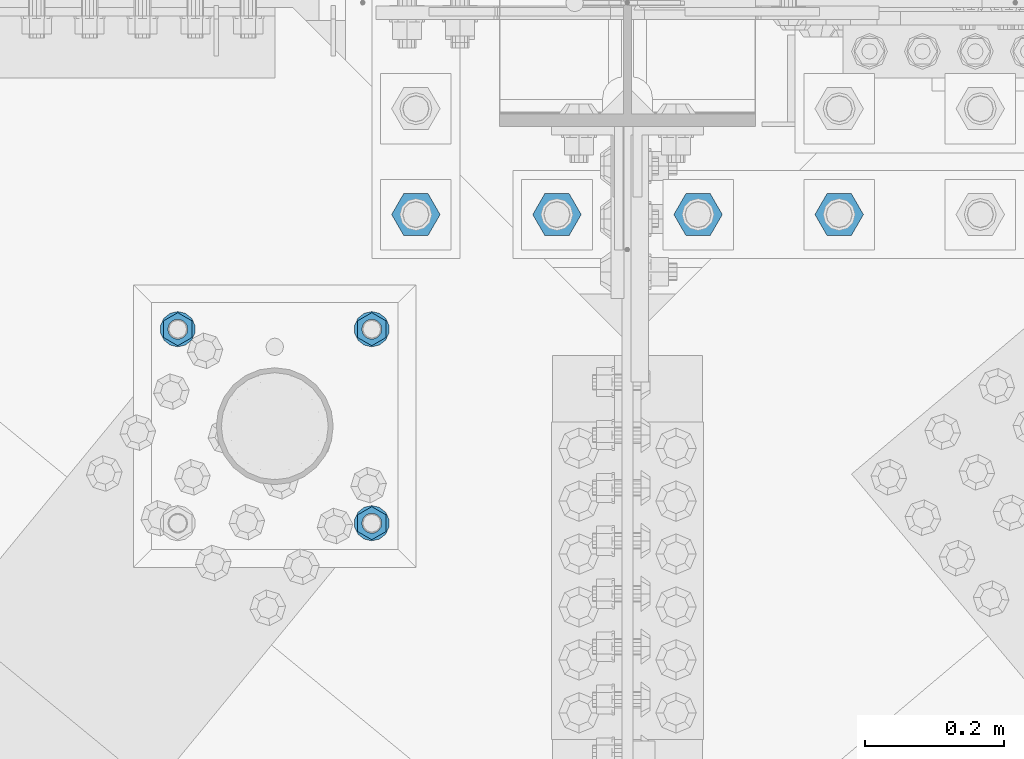
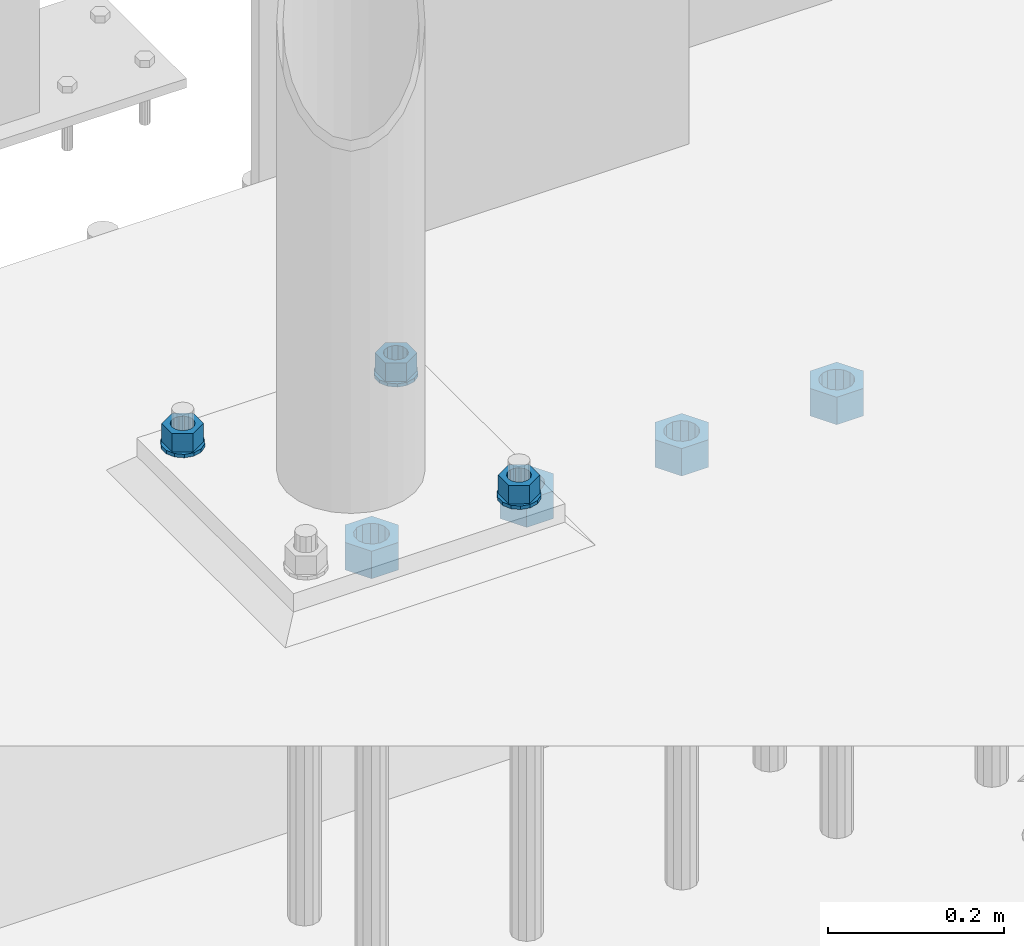
# One storey, part 1706 of 3843: 10 columns, 2 elements without a shape of their own.
"""IFC2X3 building model written with IfcOpenShell, lengths in millimetres."""

from ifc_helpers import new_model, si_unit, frame, origin_with_axes, place, context, subcontext, project, spatial, faceted_brep, material, type_object, element, aggregate, save


model = new_model("IFC2X3")

# Units and contexts
model_context = context("Model", 3, precision=1e-05, world=origin_with_axes())
body_context = subcontext(model_context, "Body", "Model", "MODEL_VIEW")
ifc_project = project(units=[si_unit("LENGTHUNIT", "METRE", prefix="MILLI"), si_unit("AREAUNIT", "SQUARE_METRE"), si_unit("VOLUMEUNIT", "CUBIC_METRE"), si_unit("MASSUNIT", "GRAM", prefix="KILO"), si_unit("TIMEUNIT", "SECOND"), si_unit("PLANEANGLEUNIT", "RADIAN"), si_unit("SOLIDANGLEUNIT", "STERADIAN"), si_unit("THERMODYNAMICTEMPERATUREUNIT", "DEGREE_CELSIUS"), si_unit("LUMINOUSINTENSITYUNIT", "LUMEN")], contexts=[model_context])

# Site, building, storey
site_placement = place(None, origin_with_axes())
site = spatial("IfcSite", under=ifc_project, at=site_placement, CompositionType="ELEMENT")
building_placement = place(site_placement, origin_with_axes())
building = spatial("IfcBuilding", under=site, at=building_placement, Name="Undefined", CompositionType="ELEMENT")
storey_placement = place(building_placement, origin_with_axes())
storey = spatial("IfcBuildingStorey", under=building, at=storey_placement, Name="Undefined", CompositionType="ELEMENT", Elevation=0.0)

# Assembly, columns
assembly_1_placement = place(storey_placement, origin_with_axes())
assembly_1 = element("IfcElementAssembly", 1, at=assembly_1_placement, inside=storey, Name="TEMPLATE", AssemblyPlace="NOTDEFINED", PredefinedType="RIGID_FRAME")
ifc_material = material(Name="STEEL/A572-50")
column_type_1 = type_object("IfcColumnType", Name="1_HEAVY_HEX_NUT", PredefinedType="NOTDEFINED")
column_1_placement = place(assembly_1_placement, frame((48628.3, 91465.4, 30560.9625), z_axis=(1.0, 0.0, 0.0), x_axis=(0.0, 0.0, -1.0)))
column_1 = element("IfcColumn", 2, at=column_1_placement, type_object=column_type_1, material=ifc_material, Name="NUT", ObjectType="1_HEAVY_HEX_NUT", context=body_context, shape_type="Brep", body=[
    faceted_brep([(0.0, -23.8099994659424, 0.0), (0.0, -11.9099998474121, -20.6200008392334), (25.3999999999978, -11.9099998474121, -20.6200008392334), (25.3999999999978, -23.8099994659424, 0.0), (0.0, 11.9099998474121, -20.6200008392334), (25.3999999999978, 11.9099998474121, -20.6200008392334), (0.0, 23.8099994659424, 0.0), (25.3999999999978, 23.8099994659424, 0.0), (0.0, 11.9099998474121, 20.6200008392334), (25.3999999999978, 11.9099998474121, 20.6200008392334), (0.0, -11.9099998474121, 20.6200008392334), (25.3999999999978, -11.9099998474121, 20.6200008392334), (0.0, 0.0, 14.289999961853), (0.0, 6.20019861543551, 12.8748450879575), (25.3999999999978, 6.20019861543551, 12.8748450879575), (25.3999999999978, 0.0, 14.289999961853), (0.0, 11.1723718546418, 8.90966924477834), (25.3999999999978, 11.1723718546418, 8.90966924477834), (0.0, 13.9317198278877, 3.17982413774735), (25.3999999999978, 13.9317198278877, 3.17982413774735), (0.0, 13.9317198278877, -3.17982413774735), (25.3999999999978, 13.9317198278877, -3.17982413774735), (0.0, 11.1723718546418, -8.90966924477834), (25.3999999999978, 11.1723718546418, -8.90966924477834), (0.0, 6.20019861543551, -12.8748450879575), (25.3999999999978, 6.20019861543551, -12.8748450879575), (0.0, 0.0, -14.289999961853), (25.3999999999978, 0.0, -14.289999961853), (0.0, -6.20019861543551, -12.8748450879575), (25.3999999999978, -6.20019861543551, -12.8748450879575), (0.0, -11.1723718546418, -8.90966924477834), (25.3999999999978, -11.1723718546418, -8.90966924477834), (0.0, -13.9317198278877, -3.17982413774735), (25.3999999999978, -13.9317198278877, -3.17982413774735), (0.0, -13.9317198278877, 3.17982413774735), (25.3999999999978, -13.9317198278877, 3.17982413774735), (0.0, -11.1723718546418, 8.90966924477834), (25.3999999999978, -11.1723718546418, 8.90966924477834), (0.0, -6.20019861543551, 12.8748450879575), (25.3999999999978, -6.20019861543551, 12.8748450879575)], [[[0, 1, 2, 3]], [[1, 4, 5, 2]], [[4, 6, 7, 5]], [[6, 8, 9, 7]], [[8, 10, 11, 9]], [[10, 0, 3, 11]], [[12, 13, 14, 15]], [[13, 16, 17, 14]], [[16, 18, 19, 17]], [[18, 20, 21, 19]], [[20, 22, 23, 21]], [[22, 24, 25, 23]], [[24, 26, 27, 25]], [[26, 28, 29, 27]], [[28, 30, 31, 29]], [[30, 32, 33, 31]], [[32, 34, 35, 33]], [[34, 36, 37, 35]], [[36, 38, 39, 37]], [[38, 12, 15, 39]], [[5, 7, 9, 11, 3, 2], [17, 19, 21, 23, 25, 27, 29, 31, 33, 35, 37, 39, 15, 14]], [[10, 8, 6, 4, 1, 0], [38, 36, 34, 32, 30, 28, 26, 24, 22, 20, 18, 16, 13, 12]]]),
])
column_2_placement = place(assembly_1_placement, frame((48628.3, 91744.8, 30560.9625), z_axis=(-1.0, 0.0, 0.0), x_axis=(0.0, 0.0, -1.0)))
column_2 = element("IfcColumn", 3, at=column_2_placement, type_object=column_type_1, material=ifc_material, Name="NUT", ObjectType="1_HEAVY_HEX_NUT", context=body_context, shape_type="Brep", body=[
    faceted_brep([(0.0, -23.8099994659424, 0.0), (0.0, -11.9099998474121, -20.6200008392334), (25.3999999999978, -11.9099998474121, -20.6200008392334), (25.3999999999978, -23.8099994659424, 0.0), (0.0, 11.9099998474121, -20.6200008392334), (25.3999999999978, 11.9099998474121, -20.6200008392334), (0.0, 23.8099994659424, 0.0), (25.3999999999978, 23.8099994659424, 0.0), (0.0, 11.9099998474121, 20.6200008392334), (25.3999999999978, 11.9099998474121, 20.6200008392334), (0.0, -11.9099998474121, 20.6200008392334), (25.3999999999978, -11.9099998474121, 20.6200008392334), (0.0, 0.0, 14.289999961853), (0.0, 6.20019861543551, 12.8748450879575), (25.3999999999978, 6.20019861543551, 12.8748450879575), (25.3999999999978, 0.0, 14.289999961853), (0.0, 11.1723718546418, 8.90966924477834), (25.3999999999978, 11.1723718546418, 8.90966924477834), (0.0, 13.9317198278877, 3.17982413774735), (25.3999999999978, 13.9317198278877, 3.17982413774735), (0.0, 13.9317198278877, -3.17982413774735), (25.3999999999978, 13.9317198278877, -3.17982413774735), (0.0, 11.1723718546418, -8.90966924477834), (25.3999999999978, 11.1723718546418, -8.90966924477834), (0.0, 6.20019861543551, -12.8748450879575), (25.3999999999978, 6.20019861543551, -12.8748450879575), (0.0, 0.0, -14.289999961853), (25.3999999999978, 0.0, -14.289999961853), (0.0, -6.20019861543551, -12.8748450879575), (25.3999999999978, -6.20019861543551, -12.8748450879575), (0.0, -11.1723718546418, -8.90966924477834), (25.3999999999978, -11.1723718546418, -8.90966924477834), (0.0, -13.9317198278877, -3.17982413774735), (25.3999999999978, -13.9317198278877, -3.17982413774735), (0.0, -13.9317198278877, 3.17982413774735), (25.3999999999978, -13.9317198278877, 3.17982413774735), (0.0, -11.1723718546418, 8.90966924477834), (25.3999999999978, -11.1723718546418, 8.90966924477834), (0.0, -6.20019861543551, 12.8748450879575), (25.3999999999978, -6.20019861543551, 12.8748450879575)], [[[0, 1, 2, 3]], [[1, 4, 5, 2]], [[4, 6, 7, 5]], [[6, 8, 9, 7]], [[8, 10, 11, 9]], [[10, 0, 3, 11]], [[12, 13, 14, 15]], [[13, 16, 17, 14]], [[16, 18, 19, 17]], [[18, 20, 21, 19]], [[20, 22, 23, 21]], [[22, 24, 25, 23]], [[24, 26, 27, 25]], [[26, 28, 29, 27]], [[28, 30, 31, 29]], [[30, 32, 33, 31]], [[32, 34, 35, 33]], [[34, 36, 37, 35]], [[36, 38, 39, 37]], [[38, 12, 15, 39]], [[5, 7, 9, 11, 3, 2], [17, 19, 21, 23, 25, 27, 29, 31, 33, 35, 37, 39, 15, 14]], [[10, 8, 6, 4, 1, 0], [38, 36, 34, 32, 30, 28, 26, 24, 22, 20, 18, 16, 13, 12]]]),
])
column_3_placement = place(assembly_1_placement, frame((48348.9, 91744.8, 30560.9625), z_axis=(-1.0, 0.0, 0.0), x_axis=(0.0, 0.0, -1.0)))
column_3 = element("IfcColumn", 4, at=column_3_placement, type_object=column_type_1, material=ifc_material, Name="NUT", ObjectType="1_HEAVY_HEX_NUT", context=body_context, shape_type="Brep", body=[
    faceted_brep([(0.0, -23.8099994659424, 0.0), (0.0, -11.9099998474121, -20.6200008392334), (25.3999999999978, -11.9099998474121, -20.6200008392334), (25.3999999999978, -23.8099994659424, 0.0), (0.0, 11.9099998474121, -20.6200008392334), (25.3999999999978, 11.9099998474121, -20.6200008392334), (0.0, 23.8099994659424, 0.0), (25.3999999999978, 23.8099994659424, 0.0), (0.0, 11.9099998474121, 20.6200008392334), (25.3999999999978, 11.9099998474121, 20.6200008392334), (0.0, -11.9099998474121, 20.6200008392334), (25.3999999999978, -11.9099998474121, 20.6200008392334), (0.0, 0.0, 14.289999961853), (0.0, 6.20019861543551, 12.8748450879575), (25.3999999999978, 6.20019861543551, 12.8748450879575), (25.3999999999978, 0.0, 14.289999961853), (0.0, 11.1723718546418, 8.90966924477834), (25.3999999999978, 11.1723718546418, 8.90966924477834), (0.0, 13.9317198278877, 3.17982413774735), (25.3999999999978, 13.9317198278877, 3.17982413774735), (0.0, 13.9317198278877, -3.17982413774735), (25.3999999999978, 13.9317198278877, -3.17982413774735), (0.0, 11.1723718546418, -8.90966924477834), (25.3999999999978, 11.1723718546418, -8.90966924477834), (0.0, 6.20019861543551, -12.8748450879575), (25.3999999999978, 6.20019861543551, -12.8748450879575), (0.0, 0.0, -14.289999961853), (25.3999999999978, 0.0, -14.289999961853), (0.0, -6.20019861543551, -12.8748450879575), (25.3999999999978, -6.20019861543551, -12.8748450879575), (0.0, -11.1723718546418, -8.90966924477834), (25.3999999999978, -11.1723718546418, -8.90966924477834), (0.0, -13.9317198278877, -3.17982413774735), (25.3999999999978, -13.9317198278877, -3.17982413774735), (0.0, -13.9317198278877, 3.17982413774735), (25.3999999999978, -13.9317198278877, 3.17982413774735), (0.0, -11.1723718546418, 8.90966924477834), (25.3999999999978, -11.1723718546418, 8.90966924477834), (0.0, -6.20019861543551, 12.8748450879575), (25.3999999999978, -6.20019861543551, 12.8748450879575)], [[[0, 1, 2, 3]], [[1, 4, 5, 2]], [[4, 6, 7, 5]], [[6, 8, 9, 7]], [[8, 10, 11, 9]], [[10, 0, 3, 11]], [[12, 13, 14, 15]], [[13, 16, 17, 14]], [[16, 18, 19, 17]], [[18, 20, 21, 19]], [[20, 22, 23, 21]], [[22, 24, 25, 23]], [[24, 26, 27, 25]], [[26, 28, 29, 27]], [[28, 30, 31, 29]], [[30, 32, 33, 31]], [[32, 34, 35, 33]], [[34, 36, 37, 35]], [[36, 38, 39, 37]], [[38, 12, 15, 39]], [[5, 7, 9, 11, 3, 2], [17, 19, 21, 23, 25, 27, 29, 31, 33, 35, 37, 39, 15, 14]], [[10, 8, 6, 4, 1, 0], [38, 36, 34, 32, 30, 28, 26, 24, 22, 20, 18, 16, 13, 12]]]),
])
column_type_2 = type_object("IfcColumnType", Name="1_WASHER", PredefinedType="NOTDEFINED")
column_4_placement = place(assembly_1_placement, frame((48628.3, 91465.4, 30535.5625), z_axis=(1.0, 0.0, 0.0), x_axis=(0.0, 0.0, -1.0)))
column_4 = element("IfcColumn", 5, at=column_4_placement, type_object=column_type_2, material=ifc_material, Name="WASHER", ObjectType="1_WASHER", context=body_context, shape_type="Brep", body=[
    faceted_brep([(0.0, -25.3999996185303, 0.0), (0.0, -22.8846089010331, -11.0206468080723), (4.76250000000073, -22.8846089010331, -11.0206468080723), (4.76250000000073, -25.3999996185303, 0.0), (0.0, -15.8366407293652, -19.8585193564431), (4.76250000000073, -15.8366407293652, -19.8585193564431), (0.0, -5.6520316376118, -24.7631685975139), (4.76250000000073, -5.6520316376118, -24.7631685975139), (0.0, 5.6520316376118, -24.7631685975139), (4.76250000000073, 5.6520316376118, -24.7631685975139), (0.0, 15.8366407293652, -19.8585193564431), (4.76250000000073, 15.8366407293652, -19.8585193564431), (0.0, 22.8846089010331, -11.0206468080723), (4.76250000000073, 22.8846089010331, -11.0206468080723), (0.0, 25.3999996185303, 0.0), (4.76250000000073, 25.3999996185303, 0.0), (0.0, 22.8846089010331, 11.0206468080723), (4.76250000000073, 22.8846089010331, 11.0206468080723), (0.0, 15.8366407293652, 19.8585193564431), (4.76250000000073, 15.8366407293652, 19.8585193564431), (0.0, 5.6520316376118, 24.7631685975139), (4.76250000000073, 5.6520316376118, 24.7631685975139), (0.0, -5.6520316376118, 24.7631685975139), (4.76250000000073, -5.6520316376118, 24.7631685975139), (0.0, -15.8366407293652, 19.8585193564431), (4.76250000000073, -15.8366407293652, 19.8585193564431), (0.0, -22.8846089010331, 11.0206468080723), (4.76250000000073, -22.8846089010331, 11.0206468080723), (0.0, 0.0, 14.289999961853), (0.0, 6.20019861543551, 12.8748450879575), (4.76250000000073, 6.20019861543551, 12.8748450879575), (4.76250000000073, 0.0, 14.289999961853), (0.0, 11.1723718546418, 8.90966924477834), (4.76250000000073, 11.1723718546418, 8.90966924477834), (0.0, 13.9317198278877, 3.17982413774735), (4.76250000000073, 13.9317198278877, 3.17982413774735), (0.0, 13.9317198278877, -3.17982413774735), (4.76250000000073, 13.9317198278877, -3.17982413774735), (0.0, 11.1723718546418, -8.90966924477834), (4.76250000000073, 11.1723718546418, -8.90966924477834), (0.0, 6.20019861543551, -12.8748450879575), (4.76250000000073, 6.20019861543551, -12.8748450879575), (0.0, 0.0, -14.289999961853), (4.76250000000073, 0.0, -14.289999961853), (0.0, -6.20019861543551, -12.8748450879575), (4.76250000000073, -6.20019861543551, -12.8748450879575), (0.0, -11.1723718546418, -8.90966924477834), (4.76250000000073, -11.1723718546418, -8.90966924477834), (0.0, -13.9317198278877, -3.17982413774735), (4.76250000000073, -13.9317198278877, -3.17982413774735), (0.0, -13.9317198278877, 3.17982413774735), (4.76250000000073, -13.9317198278877, 3.17982413774735), (0.0, -11.1723718546418, 8.90966924477834), (4.76250000000073, -11.1723718546418, 8.90966924477834), (0.0, -6.20019861543551, 12.8748450879575), (4.76250000000073, -6.20019861543551, 12.8748450879575)], [[[0, 1, 2, 3]], [[1, 4, 5, 2]], [[4, 6, 7, 5]], [[6, 8, 9, 7]], [[8, 10, 11, 9]], [[10, 12, 13, 11]], [[12, 14, 15, 13]], [[14, 16, 17, 15]], [[16, 18, 19, 17]], [[18, 20, 21, 19]], [[20, 22, 23, 21]], [[22, 24, 25, 23]], [[24, 26, 27, 25]], [[26, 0, 3, 27]], [[28, 29, 30, 31]], [[29, 32, 33, 30]], [[32, 34, 35, 33]], [[34, 36, 37, 35]], [[36, 38, 39, 37]], [[38, 40, 41, 39]], [[40, 42, 43, 41]], [[42, 44, 45, 43]], [[44, 46, 47, 45]], [[46, 48, 49, 47]], [[48, 50, 51, 49]], [[50, 52, 53, 51]], [[52, 54, 55, 53]], [[54, 28, 31, 55]], [[5, 7, 9, 11, 13, 15, 17, 19, 21, 23, 25, 27, 3, 2], [33, 35, 37, 39, 41, 43, 45, 47, 49, 51, 53, 55, 31, 30]], [[26, 24, 22, 20, 18, 16, 14, 12, 10, 8, 6, 4, 1, 0], [54, 52, 50, 48, 46, 44, 42, 40, 38, 36, 34, 32, 29, 28]]]),
])
column_5_placement = place(assembly_1_placement, frame((48628.3, 91744.8, 30535.5625), z_axis=(-1.0, 0.0, 0.0), x_axis=(0.0, 0.0, -1.0)))
column_5 = element("IfcColumn", 6, at=column_5_placement, type_object=column_type_2, material=ifc_material, Name="WASHER", ObjectType="1_WASHER", context=body_context, shape_type="Brep", body=[
    faceted_brep([(0.0, -25.3999996185303, 0.0), (0.0, -22.8846089010331, -11.0206468080723), (4.76250000000073, -22.8846089010331, -11.0206468080723), (4.76250000000073, -25.3999996185303, 0.0), (0.0, -15.8366407293652, -19.8585193564431), (4.76250000000073, -15.8366407293652, -19.8585193564431), (0.0, -5.6520316376118, -24.7631685975139), (4.76250000000073, -5.6520316376118, -24.7631685975139), (0.0, 5.6520316376118, -24.7631685975139), (4.76250000000073, 5.6520316376118, -24.7631685975139), (0.0, 15.8366407293652, -19.8585193564431), (4.76250000000073, 15.8366407293652, -19.8585193564431), (0.0, 22.8846089010331, -11.0206468080723), (4.76250000000073, 22.8846089010331, -11.0206468080723), (0.0, 25.3999996185303, 0.0), (4.76250000000073, 25.3999996185303, 0.0), (0.0, 22.8846089010331, 11.0206468080723), (4.76250000000073, 22.8846089010331, 11.0206468080723), (0.0, 15.8366407293652, 19.8585193564431), (4.76250000000073, 15.8366407293652, 19.8585193564431), (0.0, 5.6520316376118, 24.7631685975139), (4.76250000000073, 5.6520316376118, 24.7631685975139), (0.0, -5.6520316376118, 24.7631685975139), (4.76250000000073, -5.6520316376118, 24.7631685975139), (0.0, -15.8366407293652, 19.8585193564431), (4.76250000000073, -15.8366407293652, 19.8585193564431), (0.0, -22.8846089010331, 11.0206468080723), (4.76250000000073, -22.8846089010331, 11.0206468080723), (0.0, 0.0, 14.289999961853), (0.0, 6.20019861543551, 12.8748450879575), (4.76250000000073, 6.20019861543551, 12.8748450879575), (4.76250000000073, 0.0, 14.289999961853), (0.0, 11.1723718546418, 8.90966924477834), (4.76250000000073, 11.1723718546418, 8.90966924477834), (0.0, 13.9317198278877, 3.17982413774735), (4.76250000000073, 13.9317198278877, 3.17982413774735), (0.0, 13.9317198278877, -3.17982413774735), (4.76250000000073, 13.9317198278877, -3.17982413774735), (0.0, 11.1723718546418, -8.90966924477834), (4.76250000000073, 11.1723718546418, -8.90966924477834), (0.0, 6.20019861543551, -12.8748450879575), (4.76250000000073, 6.20019861543551, -12.8748450879575), (0.0, 0.0, -14.289999961853), (4.76250000000073, 0.0, -14.289999961853), (0.0, -6.20019861543551, -12.8748450879575), (4.76250000000073, -6.20019861543551, -12.8748450879575), (0.0, -11.1723718546418, -8.90966924477834), (4.76250000000073, -11.1723718546418, -8.90966924477834), (0.0, -13.9317198278877, -3.17982413774735), (4.76250000000073, -13.9317198278877, -3.17982413774735), (0.0, -13.9317198278877, 3.17982413774735), (4.76250000000073, -13.9317198278877, 3.17982413774735), (0.0, -11.1723718546418, 8.90966924477834), (4.76250000000073, -11.1723718546418, 8.90966924477834), (0.0, -6.20019861543551, 12.8748450879575), (4.76250000000073, -6.20019861543551, 12.8748450879575)], [[[0, 1, 2, 3]], [[1, 4, 5, 2]], [[4, 6, 7, 5]], [[6, 8, 9, 7]], [[8, 10, 11, 9]], [[10, 12, 13, 11]], [[12, 14, 15, 13]], [[14, 16, 17, 15]], [[16, 18, 19, 17]], [[18, 20, 21, 19]], [[20, 22, 23, 21]], [[22, 24, 25, 23]], [[24, 26, 27, 25]], [[26, 0, 3, 27]], [[28, 29, 30, 31]], [[29, 32, 33, 30]], [[32, 34, 35, 33]], [[34, 36, 37, 35]], [[36, 38, 39, 37]], [[38, 40, 41, 39]], [[40, 42, 43, 41]], [[42, 44, 45, 43]], [[44, 46, 47, 45]], [[46, 48, 49, 47]], [[48, 50, 51, 49]], [[50, 52, 53, 51]], [[52, 54, 55, 53]], [[54, 28, 31, 55]], [[5, 7, 9, 11, 13, 15, 17, 19, 21, 23, 25, 27, 3, 2], [33, 35, 37, 39, 41, 43, 45, 47, 49, 51, 53, 55, 31, 30]], [[26, 24, 22, 20, 18, 16, 14, 12, 10, 8, 6, 4, 1, 0], [54, 52, 50, 48, 46, 44, 42, 40, 38, 36, 34, 32, 29, 28]]]),
])
column_6_placement = place(assembly_1_placement, frame((48348.9, 91744.8, 30535.5625), z_axis=(-1.0, 0.0, 0.0), x_axis=(0.0, 0.0, -1.0)))
column_6 = element("IfcColumn", 7, at=column_6_placement, type_object=column_type_2, material=ifc_material, Name="WASHER", ObjectType="1_WASHER", context=body_context, shape_type="Brep", body=[
    faceted_brep([(0.0, -25.3999996185303, 0.0), (0.0, -22.8846089010331, -11.0206468080723), (4.76250000000073, -22.8846089010331, -11.0206468080723), (4.76250000000073, -25.3999996185303, 0.0), (0.0, -15.8366407293652, -19.8585193564431), (4.76250000000073, -15.8366407293652, -19.8585193564431), (0.0, -5.6520316376118, -24.7631685975139), (4.76250000000073, -5.6520316376118, -24.7631685975139), (0.0, 5.6520316376118, -24.7631685975139), (4.76250000000073, 5.6520316376118, -24.7631685975139), (0.0, 15.8366407293652, -19.8585193564431), (4.76250000000073, 15.8366407293652, -19.8585193564431), (0.0, 22.8846089010331, -11.0206468080723), (4.76250000000073, 22.8846089010331, -11.0206468080723), (0.0, 25.3999996185303, 0.0), (4.76250000000073, 25.3999996185303, 0.0), (0.0, 22.8846089010331, 11.0206468080723), (4.76250000000073, 22.8846089010331, 11.0206468080723), (0.0, 15.8366407293652, 19.8585193564431), (4.76250000000073, 15.8366407293652, 19.8585193564431), (0.0, 5.6520316376118, 24.7631685975139), (4.76250000000073, 5.6520316376118, 24.7631685975139), (0.0, -5.6520316376118, 24.7631685975139), (4.76250000000073, -5.6520316376118, 24.7631685975139), (0.0, -15.8366407293652, 19.8585193564431), (4.76250000000073, -15.8366407293652, 19.8585193564431), (0.0, -22.8846089010331, 11.0206468080723), (4.76250000000073, -22.8846089010331, 11.0206468080723), (0.0, 0.0, 14.289999961853), (0.0, 6.20019861543551, 12.8748450879575), (4.76250000000073, 6.20019861543551, 12.8748450879575), (4.76250000000073, 0.0, 14.289999961853), (0.0, 11.1723718546418, 8.90966924477834), (4.76250000000073, 11.1723718546418, 8.90966924477834), (0.0, 13.9317198278877, 3.17982413774735), (4.76250000000073, 13.9317198278877, 3.17982413774735), (0.0, 13.9317198278877, -3.17982413774735), (4.76250000000073, 13.9317198278877, -3.17982413774735), (0.0, 11.1723718546418, -8.90966924477834), (4.76250000000073, 11.1723718546418, -8.90966924477834), (0.0, 6.20019861543551, -12.8748450879575), (4.76250000000073, 6.20019861543551, -12.8748450879575), (0.0, 0.0, -14.289999961853), (4.76250000000073, 0.0, -14.289999961853), (0.0, -6.20019861543551, -12.8748450879575), (4.76250000000073, -6.20019861543551, -12.8748450879575), (0.0, -11.1723718546418, -8.90966924477834), (4.76250000000073, -11.1723718546418, -8.90966924477834), (0.0, -13.9317198278877, -3.17982413774735), (4.76250000000073, -13.9317198278877, -3.17982413774735), (0.0, -13.9317198278877, 3.17982413774735), (4.76250000000073, -13.9317198278877, 3.17982413774735), (0.0, -11.1723718546418, 8.90966924477834), (4.76250000000073, -11.1723718546418, 8.90966924477834), (0.0, -6.20019861543551, 12.8748450879575), (4.76250000000073, -6.20019861543551, 12.8748450879575)], [[[0, 1, 2, 3]], [[1, 4, 5, 2]], [[4, 6, 7, 5]], [[6, 8, 9, 7]], [[8, 10, 11, 9]], [[10, 12, 13, 11]], [[12, 14, 15, 13]], [[14, 16, 17, 15]], [[16, 18, 19, 17]], [[18, 20, 21, 19]], [[20, 22, 23, 21]], [[22, 24, 25, 23]], [[24, 26, 27, 25]], [[26, 0, 3, 27]], [[28, 29, 30, 31]], [[29, 32, 33, 30]], [[32, 34, 35, 33]], [[34, 36, 37, 35]], [[36, 38, 39, 37]], [[38, 40, 41, 39]], [[40, 42, 43, 41]], [[42, 44, 45, 43]], [[44, 46, 47, 45]], [[46, 48, 49, 47]], [[48, 50, 51, 49]], [[50, 52, 53, 51]], [[52, 54, 55, 53]], [[54, 28, 31, 55]], [[5, 7, 9, 11, 13, 15, 17, 19, 21, 23, 25, 27, 3, 2], [33, 35, 37, 39, 41, 43, 45, 47, 49, 51, 53, 55, 31, 30]], [[26, 24, 22, 20, 18, 16, 14, 12, 10, 8, 6, 4, 1, 0], [54, 52, 50, 48, 46, 44, 42, 40, 38, 36, 34, 32, 29, 28]]]),
])
aggregate(assembly_1, [column_1, column_4, column_2, column_5, column_3, column_6])

assembly_2_placement = place(storey_placement, origin_with_axes())
assembly_2 = element("IfcElementAssembly", 8, at=assembly_2_placement, inside=storey, Name="TEMPLATE", AssemblyPlace="NOTDEFINED", PredefinedType="RIGID_FRAME")
column_type_3 = type_object("IfcColumnType", Name="1-1/2_HEAVY_HEX_NUT", PredefinedType="NOTDEFINED")
column_7_placement = place(assembly_2_placement, frame((48691.8, 91909.9, 30187.9), z_axis=(0.0, -1.0, 0.0), x_axis=(0.0, 0.0, -1.0)))
column_7 = element("IfcColumn", 9, at=column_7_placement, type_object=column_type_3, material=ifc_material, Name="NUT", ObjectType="1-1/2_HEAVY_HEX_NUT", context=body_context, shape_type="Brep", body=[
    faceted_brep([(0.0, -34.9199981689453, 0.0), (0.0, -17.4599990844727, -30.25), (38.0999999999985, -17.4599990844727, -30.25), (38.0999999999985, -34.9199981689453, 0.0), (0.0, 17.4599990844727, -30.25), (38.0999999999985, 17.4599990844727, -30.25), (0.0, 34.9199981689453, 0.0), (38.0999999999985, 34.9199981689453, 0.0), (0.0, 17.4599990844727, 30.25), (38.0999999999985, 17.4599990844727, 30.25), (0.0, -17.4599990844727, 30.25), (38.0999999999985, -17.4599990844727, 30.25), (0.0, 0.0, 20.6399993896484), (0.0, 8.9553601105581, 18.5959968835959), (38.0999999999985, 8.9553601105581, 18.5959968835959), (38.0999999999985, 0.0, 20.6399993896484), (0.0, 16.1370013209525, 12.8688291298167), (38.0999999999985, 16.1370013209525, 12.8688291298167), (0.0, 20.1225115123816, 4.59283194104501), (38.0999999999985, 20.1225115123816, 4.59283194104501), (0.0, 20.1225115123816, -4.59283194104501), (38.0999999999985, 20.1225115123816, -4.59283194104501), (0.0, 16.1370013209525, -12.8688291298167), (38.0999999999985, 16.1370013209525, -12.8688291298167), (0.0, 8.9553601105581, -18.5959968835959), (38.0999999999985, 8.9553601105581, -18.5959968835959), (0.0, 0.0, -20.6399993896484), (38.0999999999985, 0.0, -20.6399993896484), (0.0, -8.9553601105581, -18.5959968835959), (38.0999999999985, -8.9553601105581, -18.5959968835959), (0.0, -16.1370013209525, -12.8688291298167), (38.0999999999985, -16.1370013209525, -12.8688291298167), (0.0, -20.1225115123816, -4.59283194104501), (38.0999999999985, -20.1225115123816, -4.59283194104501), (0.0, -20.1225115123816, 4.59283194104501), (38.0999999999985, -20.1225115123816, 4.59283194104501), (0.0, -16.1370013209525, 12.8688291298167), (38.0999999999985, -16.1370013209525, 12.8688291298167), (0.0, -8.9553601105581, 18.5959968835959), (38.0999999999985, -8.9553601105581, 18.5959968835959)], [[[0, 1, 2, 3]], [[1, 4, 5, 2]], [[4, 6, 7, 5]], [[6, 8, 9, 7]], [[8, 10, 11, 9]], [[10, 0, 3, 11]], [[12, 13, 14, 15]], [[13, 16, 17, 14]], [[16, 18, 19, 17]], [[18, 20, 21, 19]], [[20, 22, 23, 21]], [[22, 24, 25, 23]], [[24, 26, 27, 25]], [[26, 28, 29, 27]], [[28, 30, 31, 29]], [[30, 32, 33, 31]], [[32, 34, 35, 33]], [[34, 36, 37, 35]], [[36, 38, 39, 37]], [[38, 12, 15, 39]], [[5, 7, 9, 11, 3, 2], [17, 19, 21, 23, 25, 27, 29, 31, 33, 35, 37, 39, 15, 14]], [[10, 8, 6, 4, 1, 0], [38, 36, 34, 32, 30, 28, 26, 24, 22, 20, 18, 16, 13, 12]]]),
])
column_8_placement = place(assembly_2_placement, frame((48895.0, 91909.9, 30187.9), z_axis=(0.0, -1.0, 0.0), x_axis=(0.0, 0.0, -1.0)))
column_8 = element("IfcColumn", 10, at=column_8_placement, type_object=column_type_3, material=ifc_material, Name="NUT", ObjectType="1-1/2_HEAVY_HEX_NUT", context=body_context, shape_type="Brep", body=[
    faceted_brep([(0.0, -34.9199981689453, 0.0), (0.0, -17.4599990844727, -30.25), (38.0999999999985, -17.4599990844727, -30.25), (38.0999999999985, -34.9199981689453, 0.0), (0.0, 17.4599990844727, -30.25), (38.0999999999985, 17.4599990844727, -30.25), (0.0, 34.9199981689453, 0.0), (38.0999999999985, 34.9199981689453, 0.0), (0.0, 17.4599990844727, 30.25), (38.0999999999985, 17.4599990844727, 30.25), (0.0, -17.4599990844727, 30.25), (38.0999999999985, -17.4599990844727, 30.25), (0.0, 0.0, 20.6399993896484), (0.0, 8.9553601105581, 18.5959968835959), (38.0999999999985, 8.9553601105581, 18.5959968835959), (38.0999999999985, 0.0, 20.6399993896484), (0.0, 16.1370013209525, 12.8688291298167), (38.0999999999985, 16.1370013209525, 12.8688291298167), (0.0, 20.1225115123816, 4.59283194104501), (38.0999999999985, 20.1225115123816, 4.59283194104501), (0.0, 20.1225115123816, -4.59283194104501), (38.0999999999985, 20.1225115123816, -4.59283194104501), (0.0, 16.1370013209525, -12.8688291298167), (38.0999999999985, 16.1370013209525, -12.8688291298167), (0.0, 8.9553601105581, -18.5959968835959), (38.0999999999985, 8.9553601105581, -18.5959968835959), (0.0, 0.0, -20.6399993896484), (38.0999999999985, 0.0, -20.6399993896484), (0.0, -8.9553601105581, -18.5959968835959), (38.0999999999985, -8.9553601105581, -18.5959968835959), (0.0, -16.1370013209525, -12.8688291298167), (38.0999999999985, -16.1370013209525, -12.8688291298167), (0.0, -20.1225115123816, -4.59283194104501), (38.0999999999985, -20.1225115123816, -4.59283194104501), (0.0, -20.1225115123816, 4.59283194104501), (38.0999999999985, -20.1225115123816, 4.59283194104501), (0.0, -16.1370013209525, 12.8688291298167), (38.0999999999985, -16.1370013209525, 12.8688291298167), (0.0, -8.9553601105581, 18.5959968835959), (38.0999999999985, -8.9553601105581, 18.5959968835959)], [[[0, 1, 2, 3]], [[1, 4, 5, 2]], [[4, 6, 7, 5]], [[6, 8, 9, 7]], [[8, 10, 11, 9]], [[10, 0, 3, 11]], [[12, 13, 14, 15]], [[13, 16, 17, 14]], [[16, 18, 19, 17]], [[18, 20, 21, 19]], [[20, 22, 23, 21]], [[22, 24, 25, 23]], [[24, 26, 27, 25]], [[26, 28, 29, 27]], [[28, 30, 31, 29]], [[30, 32, 33, 31]], [[32, 34, 35, 33]], [[34, 36, 37, 35]], [[36, 38, 39, 37]], [[38, 12, 15, 39]], [[5, 7, 9, 11, 3, 2], [17, 19, 21, 23, 25, 27, 29, 31, 33, 35, 37, 39, 15, 14]], [[10, 8, 6, 4, 1, 0], [38, 36, 34, 32, 30, 28, 26, 24, 22, 20, 18, 16, 13, 12]]]),
])
column_9_placement = place(assembly_2_placement, frame((49098.2, 91909.9, 30187.9), z_axis=(0.0, -1.0, 0.0), x_axis=(0.0, 0.0, -1.0)))
column_9 = element("IfcColumn", 11, at=column_9_placement, type_object=column_type_3, material=ifc_material, Name="NUT", ObjectType="1-1/2_HEAVY_HEX_NUT", context=body_context, shape_type="Brep", body=[
    faceted_brep([(0.0, -34.9199981689453, 0.0), (0.0, -17.4599990844727, -30.25), (38.0999999999985, -17.4599990844727, -30.25), (38.0999999999985, -34.9199981689453, 0.0), (0.0, 17.4599990844727, -30.25), (38.0999999999985, 17.4599990844727, -30.25), (0.0, 34.9199981689453, 0.0), (38.0999999999985, 34.9199981689453, 0.0), (0.0, 17.4599990844727, 30.25), (38.0999999999985, 17.4599990844727, 30.25), (0.0, -17.4599990844727, 30.25), (38.0999999999985, -17.4599990844727, 30.25), (0.0, 0.0, 20.6399993896484), (0.0, 8.9553601105581, 18.5959968835959), (38.0999999999985, 8.9553601105581, 18.5959968835959), (38.0999999999985, 0.0, 20.6399993896484), (0.0, 16.1370013209525, 12.8688291298167), (38.0999999999985, 16.1370013209525, 12.8688291298167), (0.0, 20.1225115123816, 4.59283194104501), (38.0999999999985, 20.1225115123816, 4.59283194104501), (0.0, 20.1225115123816, -4.59283194104501), (38.0999999999985, 20.1225115123816, -4.59283194104501), (0.0, 16.1370013209525, -12.8688291298167), (38.0999999999985, 16.1370013209525, -12.8688291298167), (0.0, 8.9553601105581, -18.5959968835959), (38.0999999999985, 8.9553601105581, -18.5959968835959), (0.0, 0.0, -20.6399993896484), (38.0999999999985, 0.0, -20.6399993896484), (0.0, -8.9553601105581, -18.5959968835959), (38.0999999999985, -8.9553601105581, -18.5959968835959), (0.0, -16.1370013209525, -12.8688291298167), (38.0999999999985, -16.1370013209525, -12.8688291298167), (0.0, -20.1225115123816, -4.59283194104501), (38.0999999999985, -20.1225115123816, -4.59283194104501), (0.0, -20.1225115123816, 4.59283194104501), (38.0999999999985, -20.1225115123816, 4.59283194104501), (0.0, -16.1370013209525, 12.8688291298167), (38.0999999999985, -16.1370013209525, 12.8688291298167), (0.0, -8.9553601105581, 18.5959968835959), (38.0999999999985, -8.9553601105581, 18.5959968835959)], [[[0, 1, 2, 3]], [[1, 4, 5, 2]], [[4, 6, 7, 5]], [[6, 8, 9, 7]], [[8, 10, 11, 9]], [[10, 0, 3, 11]], [[12, 13, 14, 15]], [[13, 16, 17, 14]], [[16, 18, 19, 17]], [[18, 20, 21, 19]], [[20, 22, 23, 21]], [[22, 24, 25, 23]], [[24, 26, 27, 25]], [[26, 28, 29, 27]], [[28, 30, 31, 29]], [[30, 32, 33, 31]], [[32, 34, 35, 33]], [[34, 36, 37, 35]], [[36, 38, 39, 37]], [[38, 12, 15, 39]], [[5, 7, 9, 11, 3, 2], [17, 19, 21, 23, 25, 27, 29, 31, 33, 35, 37, 39, 15, 14]], [[10, 8, 6, 4, 1, 0], [38, 36, 34, 32, 30, 28, 26, 24, 22, 20, 18, 16, 13, 12]]]),
])
column_10_placement = place(assembly_2_placement, frame((49301.4, 91909.9, 30187.9), z_axis=(0.0, 1.0, 0.0), x_axis=(0.0, 0.0, -1.0)))
column_10 = element("IfcColumn", 12, at=column_10_placement, type_object=column_type_3, material=ifc_material, Name="NUT", ObjectType="1-1/2_HEAVY_HEX_NUT", context=body_context, shape_type="Brep", body=[
    faceted_brep([(0.0, -34.9199981689453, 0.0), (0.0, -17.4599990844727, -30.25), (38.0999999999985, -17.4599990844727, -30.25), (38.0999999999985, -34.9199981689453, 0.0), (0.0, 17.4599990844727, -30.25), (38.0999999999985, 17.4599990844727, -30.25), (0.0, 34.9199981689453, 0.0), (38.0999999999985, 34.9199981689453, 0.0), (0.0, 17.4599990844727, 30.25), (38.0999999999985, 17.4599990844727, 30.25), (0.0, -17.4599990844727, 30.25), (38.0999999999985, -17.4599990844727, 30.25), (0.0, 0.0, 20.6399993896484), (0.0, 8.9553601105581, 18.5959968835959), (38.0999999999985, 8.9553601105581, 18.5959968835959), (38.0999999999985, 0.0, 20.6399993896484), (0.0, 16.1370013209525, 12.8688291298167), (38.0999999999985, 16.1370013209525, 12.8688291298167), (0.0, 20.1225115123816, 4.59283194104501), (38.0999999999985, 20.1225115123816, 4.59283194104501), (0.0, 20.1225115123816, -4.59283194104501), (38.0999999999985, 20.1225115123816, -4.59283194104501), (0.0, 16.1370013209525, -12.8688291298167), (38.0999999999985, 16.1370013209525, -12.8688291298167), (0.0, 8.9553601105581, -18.5959968835959), (38.0999999999985, 8.9553601105581, -18.5959968835959), (0.0, 0.0, -20.6399993896484), (38.0999999999985, 0.0, -20.6399993896484), (0.0, -8.9553601105581, -18.5959968835959), (38.0999999999985, -8.9553601105581, -18.5959968835959), (0.0, -16.1370013209525, -12.8688291298167), (38.0999999999985, -16.1370013209525, -12.8688291298167), (0.0, -20.1225115123816, -4.59283194104501), (38.0999999999985, -20.1225115123816, -4.59283194104501), (0.0, -20.1225115123816, 4.59283194104501), (38.0999999999985, -20.1225115123816, 4.59283194104501), (0.0, -16.1370013209525, 12.8688291298167), (38.0999999999985, -16.1370013209525, 12.8688291298167), (0.0, -8.9553601105581, 18.5959968835959), (38.0999999999985, -8.9553601105581, 18.5959968835959)], [[[0, 1, 2, 3]], [[1, 4, 5, 2]], [[4, 6, 7, 5]], [[6, 8, 9, 7]], [[8, 10, 11, 9]], [[10, 0, 3, 11]], [[12, 13, 14, 15]], [[13, 16, 17, 14]], [[16, 18, 19, 17]], [[18, 20, 21, 19]], [[20, 22, 23, 21]], [[22, 24, 25, 23]], [[24, 26, 27, 25]], [[26, 28, 29, 27]], [[28, 30, 31, 29]], [[30, 32, 33, 31]], [[32, 34, 35, 33]], [[34, 36, 37, 35]], [[36, 38, 39, 37]], [[38, 12, 15, 39]], [[5, 7, 9, 11, 3, 2], [17, 19, 21, 23, 25, 27, 29, 31, 33, 35, 37, 39, 15, 14]], [[10, 8, 6, 4, 1, 0], [38, 36, 34, 32, 30, 28, 26, 24, 22, 20, 18, 16, 13, 12]]]),
])
aggregate(assembly_2, [column_7, column_8, column_9, column_10])

save(model, "model.ifc")
